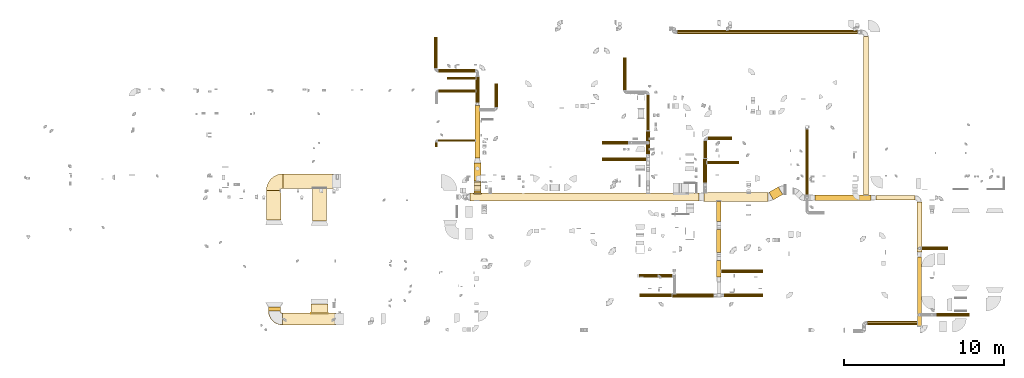
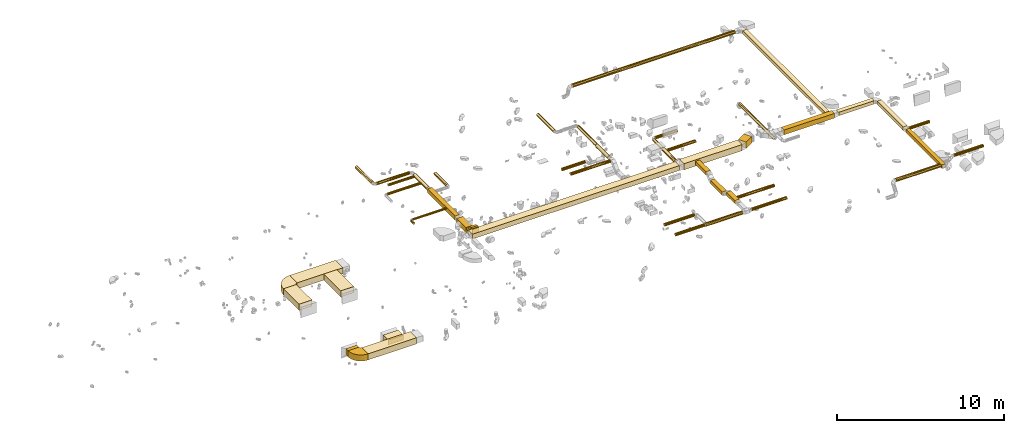
# One storey, part 1 of 62: 54 coverings.
"""IFC2X3 building model written with IfcOpenShell, lengths in millimetres."""

from ifc_helpers import new_model, entity, si_unit, converted_unit, derived_unit, direction, frame, frame_2d, origin, origin_2d_with_axis, place, context, subcontext, project, spatial, polyline, circle_curve, parameter, trimmed, segment, composite_curve, rectangle, circle, outline, extrude, element, save


model = new_model("IFC2X3")

# Units and contexts
model_context = context("Model", 3, precision=0.01, world=origin(), true_north=direction((6.12303176911189e-17, 1.0)))
body_context = subcontext(model_context, "Body", "Model", "MODEL_VIEW")
ifc_project = project(units=[si_unit("LENGTHUNIT", "METRE", prefix="MILLI"), si_unit("AREAUNIT", "SQUARE_METRE"), si_unit("VOLUMEUNIT", "CUBIC_METRE"), converted_unit("PLANEANGLEUNIT", "DEGREE", entity("IfcRatioMeasure", 0.0174532925199433), si_unit("PLANEANGLEUNIT", "RADIAN"), dimensions=[0, 0, 0, 0, 0, 0, 0]), si_unit("MASSUNIT", "GRAM", prefix="KILO"), derived_unit("MASSDENSITYUNIT", [(si_unit("MASSUNIT", "GRAM", prefix="KILO"), 1), (si_unit("LENGTHUNIT", "METRE"), -3)]), derived_unit("MOMENTOFINERTIAUNIT", [(si_unit("LENGTHUNIT", "METRE"), 4)]), si_unit("TIMEUNIT", "SECOND"), si_unit("FREQUENCYUNIT", "HERTZ"), si_unit("THERMODYNAMICTEMPERATUREUNIT", "DEGREE_CELSIUS"), derived_unit("THERMALTRANSMITTANCEUNIT", [(si_unit("MASSUNIT", "GRAM", prefix="KILO"), 1), (si_unit("THERMODYNAMICTEMPERATUREUNIT", "KELVIN"), -1), (si_unit("TIMEUNIT", "SECOND"), -3)]), derived_unit("VOLUMETRICFLOWRATEUNIT", [(si_unit("LENGTHUNIT", "METRE"), 3), (si_unit("TIMEUNIT", "SECOND"), -1)]), derived_unit("MASSFLOWRATEUNIT", [(si_unit("MASSUNIT", "GRAM", prefix="KILO"), 1), (si_unit("TIMEUNIT", "SECOND"), -1)]), derived_unit("ROTATIONALFREQUENCYUNIT", [(si_unit("TIMEUNIT", "SECOND"), -1)]), si_unit("ELECTRICCURRENTUNIT", "AMPERE"), si_unit("ELECTRICVOLTAGEUNIT", "VOLT"), si_unit("POWERUNIT", "WATT"), si_unit("FORCEUNIT", "NEWTON", prefix="KILO"), si_unit("ILLUMINANCEUNIT", "LUX"), si_unit("LUMINOUSFLUXUNIT", "LUMEN"), si_unit("LUMINOUSINTENSITYUNIT", "CANDELA"), derived_unit("USERDEFINED", [(si_unit("MASSUNIT", "GRAM", prefix="KILO"), -1), (si_unit("LENGTHUNIT", "METRE"), -2), (si_unit("TIMEUNIT", "SECOND"), 3), (si_unit("LUMINOUSFLUXUNIT", "LUMEN"), 1)]), derived_unit("LINEARVELOCITYUNIT", [(si_unit("LENGTHUNIT", "METRE"), 1), (si_unit("TIMEUNIT", "SECOND"), -1)]), si_unit("PRESSUREUNIT", "PASCAL"), derived_unit("USERDEFINED", [(si_unit("LENGTHUNIT", "METRE"), -2), (si_unit("MASSUNIT", "GRAM", prefix="KILO"), 1), (si_unit("TIMEUNIT", "SECOND"), -2)]), derived_unit("LINEARFORCEUNIT", [(si_unit("MASSUNIT", "GRAM", prefix="KILO"), 1), (si_unit("LENGTHUNIT", "METRE"), 1), (si_unit("TIMEUNIT", "SECOND"), -2), (si_unit("LENGTHUNIT", "METRE"), -1)]), derived_unit("PLANARFORCEUNIT", [(si_unit("MASSUNIT", "GRAM", prefix="KILO"), 1), (si_unit("LENGTHUNIT", "METRE"), 1), (si_unit("TIMEUNIT", "SECOND"), -2), (si_unit("LENGTHUNIT", "METRE"), -2)])], contexts=[model_context])

# Site, building, storey
site_placement = place(None, origin())
site = spatial("IfcSite", under=ifc_project, at=site_placement, CompositionType="ELEMENT")
building_placement = place(site_placement, origin())
building = spatial("IfcBuilding", under=site, at=building_placement, CompositionType="ELEMENT")
storey_placement = place(building_placement, frame((0.0, 0.0, 24000.0)))
storey = spatial("IfcBuildingStorey", under=building, at=storey_placement, CompositionType="ELEMENT", Elevation=24000.0)

# Coverings
covering_1_placement = place(storey_placement, frame((54240.7, 8649.98, 3325.0)))
element("IfcCovering", 1, at=covering_1_placement, inside=storey, PredefinedType="INSULATION", context=body_context, shape_type="SweptSolid", body=[
    extrude(rectangle(XDim=4013.85955351197, YDim=550.000000000001, at=origin_2d_with_axis()), frame((2006.93, 275.0, 0.0)), (0.0, 0.0, 1.0), 450.000000000002),
])
covering_2_placement = place(storey_placement, frame((58317.05, 8740.41, 3325.0)))
element("IfcCovering", 2, at=covering_2_placement, inside=storey, PredefinedType="INSULATION", context=body_context, shape_type="SweptSolid", body=[
    extrude(rectangle(XDim=672.825030727756, YDim=550.000000000009, at=origin_2d_with_axis()), frame((428.84, 406.36, 0.0), z_axis=(0.0, 0.0, 1.0), x_axis=(0.866025403784441, 0.499999999999996, 0.0)), (0.0, 0.0, 1.0), 450.000000000002),
])
covering_3_placement = place(storey_placement, frame((39617.06, 8674.98, 3375.0)))
element("IfcCovering", 3, at=covering_3_placement, inside=storey, PredefinedType="INSULATION", context=body_context, shape_type="SweptSolid", body=[
    extrude(rectangle(XDim=14323.633695998, YDim=500.000000000001, at=origin_2d_with_axis()), frame((7161.82, 250.0, 0.0), z_axis=(0.0, 0.0, 1.0), x_axis=(-1.0, 0.0, 0.0)), (0.0, 0.0, 1.0), 349.999999999998),
])
covering_4_placement = place(storey_placement, frame((55029.59, 7386.33, 3425.0)))
element("IfcCovering", 4, at=covering_4_placement, inside=storey, PredefinedType="INSULATION", context=body_context, shape_type="SweptSolid", body=[
    extrude(rectangle(XDim=1268.64626439159, YDim=300.000000000001, at=origin_2d_with_axis()), frame((150.0, 634.32, 0.0), z_axis=(0.0, 0.0, 1.0), x_axis=(0.0, -1.0, 0.0)), (0.0, 0.0, 1.0), 250.000000000004),
])
covering_5_placement = place(storey_placement, frame((55029.59, 5448.41, 3125.0)))
element("IfcCovering", 5, at=covering_5_placement, inside=storey, PredefinedType="INSULATION", context=body_context, shape_type="SweptSolid", body=[
    extrude(rectangle(XDim=1430.81282899736, YDim=300.000000000001, at=origin_2d_with_axis()), frame((150.0, 715.41, 0.0), z_axis=(0.0, 0.0, 1.0), x_axis=(0.0, -1.0, 0.0)), (0.0, 0.0, 1.0), 250.000000000004),
])
covering_6_placement = place(storey_placement, frame((55029.59, 3912.24, 3425.0)))
element("IfcCovering", 6, at=covering_6_placement, inside=storey, PredefinedType="INSULATION", context=body_context, shape_type="SweptSolid", body=[
    extrude(rectangle(XDim=1029.05982822021, YDim=300.000000000001, at=origin_2d_with_axis()), frame((150.0, 514.53, 0.0), z_axis=(0.0, 0.0, 1.0), x_axis=(0.0, 1.0, 0.0)), (0.0, 0.0, 1.0), 250.000000000004),
])
covering_7_placement = place(storey_placement, frame((55324.59, 4170.65, 3443.4)))
element("IfcCovering", 7, at=covering_7_placement, inside=storey, PredefinedType="INSULATION", context=body_context, shape_type="SweptSolid", body=[
    extrude(circle(Radius=105.0, at=origin_2d_with_axis()), frame((0.0, 106.6, 106.6), z_axis=(1.0, 0.0, 0.0), x_axis=(0.0, 1.0, 0.0)), (0.0, 0.0, 1.0), 2616.24999999989),
])
covering_8_placement = place(storey_placement, frame((55504.59, 2669.37, 3443.4)))
element("IfcCovering", 8, at=covering_8_placement, inside=storey, PredefinedType="INSULATION", context=body_context, shape_type="SweptSolid", body=[
    extrude(circle(Radius=105.0, at=origin_2d_with_axis()), frame((0.0, 106.6, 106.6), z_axis=(1.0, 0.0, 0.0), x_axis=(0.0, 1.0, 0.0)), (0.0, 0.0, 1.0), 2434.58382599763),
])
covering_9_placement = place(storey_placement, frame((52284.64, 2649.37, 3423.4)))
element("IfcCovering", 9, at=covering_9_placement, inside=storey, PredefinedType="INSULATION", context=body_context, shape_type="SweptSolid", body=[
    extrude(circle(Radius=125.0, at=origin_2d_with_axis()), frame((0.0, 126.6, 126.6), z_axis=(1.0, 0.0, 0.0), x_axis=(0.0, -1.0, 0.0)), (0.0, 0.0, 1.0), 2569.94435033076),
])
covering_10_placement = place(storey_placement, frame((50238.85, 2669.37, 3443.4)))
element("IfcCovering", 10, at=covering_10_placement, inside=storey, PredefinedType="INSULATION", context=body_context, shape_type="SweptSolid", body=[
    extrude(circle(Radius=105.0, at=origin_2d_with_axis()), frame((0.0, 106.6, 106.6), z_axis=(1.0, 0.0, 0.0), x_axis=(0.0, -1.0, 0.0)), (0.0, 0.0, 1.0), 2005.79291070888),
])
covering_11_placement = place(storey_placement, frame((50181.52, 3891.51, 3443.4)))
element("IfcCovering", 11, at=covering_11_placement, inside=storey, PredefinedType="INSULATION", context=body_context, shape_type="SweptSolid", body=[
    extrude(circle(Radius=105.0, at=origin_2d_with_axis()), frame((0.0, 106.6, 106.6), z_axis=(1.0, 0.0, 0.0), x_axis=(0.0, -1.0, 0.0)), (0.0, 0.0, 1.0), 2068.12499999997),
])
covering_12_placement = place(storey_placement, frame((47890.35, 11165.43, 3543.4)))
element("IfcCovering", 12, at=covering_12_placement, inside=storey, PredefinedType="INSULATION", context=body_context, shape_type="SweptSolid", body=[
    extrude(circle(Radius=105.0, at=origin_2d_with_axis()), frame((0.0, 106.6, 106.6), z_axis=(1.0, 0.0, 0.0), x_axis=(0.0, -1.0, 0.0)), (0.0, 0.0, 1.0), 2746.27416997958),
])
covering_13_placement = place(storey_placement, frame((50630.03, 11595.58, 3523.4)))
element("IfcCovering", 13, at=covering_13_placement, inside=storey, PredefinedType="INSULATION", context=body_context, shape_type="SweptSolid", body=[
    extrude(circle(Radius=125.0, at=origin_2d_with_axis()), frame((126.6, 0.0, 126.6), z_axis=(0.0, 1.0, 0.0), x_axis=(-1.0, 0.0, 0.0)), (0.0, 0.0, 1.0), 1444.99999999998),
])
covering_14_placement = place(storey_placement, frame((49195.97, 15621.83, 3543.4)))
element("IfcCovering", 14, at=covering_14_placement, inside=storey, PredefinedType="INSULATION", context=body_context, shape_type="SweptSolid", body=[
    extrude(circle(Radius=105.0, at=origin_2d_with_axis()), frame((106.6, 0.0, 106.6), z_axis=(0.0, 1.0, 0.0), x_axis=(-1.0, 0.0, 0.0)), (0.0, 0.0, 1.0), 2018.74999999999),
])
covering_15_placement = place(storey_placement, frame((50650.03, 13080.58, 3563.4)))
element("IfcCovering", 15, at=covering_15_placement, inside=storey, PredefinedType="INSULATION", context=body_context, shape_type="SweptSolid", body=[
    extrude(circle(Radius=105.0, at=origin_2d_with_axis()), frame((106.6, 0.0, 106.6), z_axis=(0.0, 1.0, 0.0), x_axis=(-1.0, 0.0, 0.0)), (0.0, 0.0, 1.0), 2221.25000000001),
])
covering_16_placement = place(storey_placement, frame((47890.35, 12203.45, 3253.4)))
element("IfcCovering", 16, at=covering_16_placement, inside=storey, PredefinedType="INSULATION", context=body_context, shape_type="SweptSolid", body=[
    extrude(circle(Radius=105.0, at=origin_2d_with_axis()), frame((0.0, 106.6, 106.6), z_axis=(1.0, 0.0, 0.0), x_axis=(0.0, -1.0, 0.0)), (0.0, 0.0, 1.0), 1600.0),
])
covering_17_placement = place(storey_placement, frame((54206.92, 9825.35, 3073.4)))
element("IfcCovering", 17, at=covering_17_placement, inside=storey, PredefinedType="INSULATION", context=body_context, shape_type="SweptSolid", body=[
    extrude(circle(Radius=125.0, at=origin_2d_with_axis()), frame((126.6, 0.0, 126.6), z_axis=(0.0, 1.0, 0.0), x_axis=(1.0, 0.0, 0.0)), (0.0, 0.0, 1.0), 1482.42358986801),
])
covering_18_placement = place(storey_placement, frame((54493.52, 12476.18, 3093.4)))
element("IfcCovering", 18, at=covering_18_placement, inside=storey, PredefinedType="INSULATION", context=body_context, shape_type="SweptSolid", body=[
    extrude(circle(Radius=105.0, at=origin_2d_with_axis()), frame((0.0, 106.6, 106.6), z_axis=(1.0, 0.0, 0.0), x_axis=(0.0, 1.0, 0.0)), (0.0, 0.0, 1.0), 1521.83766184076),
])
covering_19_placement = place(storey_placement, frame((54226.92, 11347.77, 3093.4)))
element("IfcCovering", 19, at=covering_19_placement, inside=storey, PredefinedType="INSULATION", context=body_context, shape_type="SweptSolid", body=[
    extrude(circle(Radius=105.0, at=origin_2d_with_axis()), frame((106.6, 0.0, 106.6), z_axis=(0.0, 1.0, 0.0), x_axis=(1.0, 0.0, 0.0)), (0.0, 0.0, 1.0), 1075.00000000004),
])
covering_20_placement = place(storey_placement, frame((54453.52, 10971.22, 3093.4)))
element("IfcCovering", 20, at=covering_20_placement, inside=storey, PredefinedType="INSULATION", context=body_context, shape_type="SweptSolid", body=[
    extrude(circle(Radius=105.0, at=origin_2d_with_axis()), frame((0.0, 106.6, 106.6), z_axis=(1.0, 0.0, 0.0), x_axis=(0.0, 1.0, 0.0)), (0.0, 0.0, 1.0), 1980.0),
])
covering_21_placement = place(storey_placement, frame((61191.73, 8700.02, 3425.0)))
element("IfcCovering", 21, at=covering_21_placement, inside=storey, PredefinedType="INSULATION", context=body_context, shape_type="SweptSolid", body=[
    extrude(rectangle(XDim=3500.00000000001, YDim=350.000000000001, at=origin_2d_with_axis()), frame((1750.0, 175.0, 0.0)), (0.0, 0.0, 1.0), 349.999999999998),
])
covering_22_placement = place(storey_placement, frame((64991.73, 8725.02, 3475.0)))
element("IfcCovering", 22, at=covering_22_placement, inside=storey, PredefinedType="INSULATION", context=body_context, shape_type="SweptSolid", body=[
    extrude(rectangle(XDim=2449.99999999995, YDim=300.000000000001, at=origin_2d_with_axis()), frame((1225.0, 150.0, 0.0)), (0.0, 0.0, 1.0), 250.000000000004),
])
covering_23_placement = place(storey_placement, frame((67566.73, 5468.12, 3475.0)))
element("IfcCovering", 23, at=covering_23_placement, inside=storey, PredefinedType="INSULATION", context=body_context, shape_type="SweptSolid", body=[
    extrude(rectangle(XDim=3131.89999999988, YDim=300.000000000001, at=origin_2d_with_axis()), frame((150.0, 1565.95, 0.0), z_axis=(0.0, 0.0, 1.0), x_axis=(0.0, -1.0, 0.0)), (0.0, 0.0, 1.0), 250.000000000004),
])
covering_24_placement = place(storey_placement, frame((67591.73, 868.12, 3475.0)))
element("IfcCovering", 24, at=covering_24_placement, inside=storey, PredefinedType="INSULATION", context=body_context, shape_type="SweptSolid", body=[
    extrude(rectangle(XDim=4300.00000000001, YDim=249.999999999995, at=origin_2d_with_axis()), frame((125.0, 2150.0, 0.0), z_axis=(0.0, 0.0, 1.0), x_axis=(0.0, -1.0, 0.0)), (0.0, 0.0, 1.0), 250.000000000008),
])
covering_25_placement = place(storey_placement, frame((60582.25, 9055.62, 3053.4)))
element("IfcCovering", 25, at=covering_25_placement, inside=storey, PredefinedType="INSULATION", context=body_context, shape_type="SweptSolid", body=[
    extrude(circle(Radius=105.0, at=origin_2d_with_axis()), frame((106.6, 0.0, 106.6), z_axis=(0.0, 1.0, 0.0), x_axis=(1.0, 0.0, 0.0)), (0.0, 0.0, 1.0), 4090.0),
])
covering_26_placement = place(storey_placement, frame((64232.65, 9045.02, 3525.0)))
element("IfcCovering", 26, at=covering_26_placement, inside=storey, PredefinedType="INSULATION", context=body_context, shape_type="SweptSolid", body=[
    extrude(rectangle(XDim=9908.10000000008, YDim=300.000000000001, at=origin_2d_with_axis()), frame((150.0, 4954.05, 0.0), z_axis=(0.0, 0.0, 1.0), x_axis=(0.0, 1.0, 0.0)), (0.0, 0.0, 1.0), 250.000000000004),
])
covering_27_placement = place(storey_placement, frame((52590.65, 19101.53, 3523.4)))
element("IfcCovering", 27, at=covering_27_placement, inside=storey, PredefinedType="INSULATION", context=body_context, shape_type="SweptSolid", body=[
    extrude(circle(Radius=125.0, at=origin_2d_with_axis()), frame((0.0, 126.6, 126.6), z_axis=(1.0, 0.0, 0.0), x_axis=(0.0, -1.0, 0.0)), (0.0, 0.0, 1.0), 11251.9965340593),
])
covering_28_placement = place(storey_placement, frame((67876.73, 5604.78, 3193.4)))
element("IfcCovering", 28, at=covering_28_placement, inside=storey, PredefinedType="INSULATION", context=body_context, shape_type="SweptSolid", body=[
    extrude(circle(Radius=105.0, at=origin_2d_with_axis()), frame((0.0, 106.6, 106.6), z_axis=(1.0, 0.0, 0.0), x_axis=(0.0, 1.0, 0.0)), (0.0, 0.0, 1.0), 1640.00000000001),
])
covering_29_placement = place(storey_placement, frame((68803.0, 1444.8, 3493.4)))
element("IfcCovering", 29, at=covering_29_placement, inside=storey, PredefinedType="INSULATION", context=body_context, shape_type="SweptSolid", body=[
    extrude(circle(Radius=105.0, at=origin_2d_with_axis()), frame((0.0, 106.6, 106.6), z_axis=(1.0, 0.0, 0.0), x_axis=(0.0, 1.0, 0.0)), (0.0, 0.0, 1.0), 2033.72583002031),
])
covering_30_placement = place(storey_placement, frame((64469.87, 923.29, 3473.4)))
element("IfcCovering", 30, at=covering_30_placement, inside=storey, PredefinedType="INSULATION", context=body_context, shape_type="SweptSolid", body=[
    extrude(circle(Radius=125.0, at=origin_2d_with_axis()), frame((0.0, 126.6, 126.6), z_axis=(1.0, 0.0, 0.0), x_axis=(0.0, -1.0, 0.0)), (0.0, 0.0, 1.0), 3126.86241545841),
])
covering_31_placement = place(storey_placement, frame((39945.11, 11346.34, 3020.0)))
element("IfcCovering", 31, at=covering_31_placement, inside=storey, PredefinedType="INSULATION", context=body_context, shape_type="SweptSolid", body=[
    extrude(rectangle(XDim=3279.99999999988, YDim=300.000000000001, at=origin_2d_with_axis()), frame((150.0, 1640.0, 0.0), z_axis=(0.0, 0.0, 1.0), x_axis=(0.0, -1.0, 0.0)), (0.0, 0.0, 1.0), 300.000000000001),
])
covering_32_placement = place(storey_placement, frame((39870.11, 9933.64, 2995.0)))
element("IfcCovering", 32, at=covering_32_placement, inside=storey, PredefinedType="INSULATION", context=body_context, shape_type="SweptSolid", body=[
    extrude(rectangle(XDim=1112.69724297037, YDim=450.000000000002, at=origin_2d_with_axis()), frame((225.0, 556.35, 0.0), z_axis=(0.0, 0.0, 1.0), x_axis=(0.0, -1.0, 0.0)), (0.0, 0.0, 1.0), 349.999999999998),
])
covering_33_placement = place(storey_placement, frame((39870.11, 9118.88, 3375.0)))
element("IfcCovering", 33, at=covering_33_placement, inside=storey, PredefinedType="INSULATION", context=body_context, shape_type="SweptSolid", body=[
    extrude(rectangle(XDim=450.000000000002, YDim=51.0959999999994, at=origin_2d_with_axis()), frame((225.0, 25.55, 0.0), z_axis=(0.0, 0.0, 1.0), x_axis=(-1.0, 0.0, 0.0)), (0.0, 0.0, 1.0), 349.999999999998),
])
covering_34_placement = place(storey_placement, frame((39870.11, 9169.98, 3375.0)))
element("IfcCovering", 34, at=covering_34_placement, inside=storey, PredefinedType="INSULATION", context=body_context, shape_type="SweptSolid", body=[
    extrude(rectangle(XDim=135.135931288061, YDim=450.000000000002, at=origin_2d_with_axis()), frame((225.0, 67.57, 0.0), z_axis=(0.0, 0.0, 1.0), x_axis=(0.0, 1.0, 0.0)), (0.0, 0.0, 1.0), 349.999999999998),
])
covering_35_placement = place(storey_placement, frame((39870.11, 9393.5, 3134.12)))
element("IfcCovering", 35, at=covering_35_placement, inside=storey, PredefinedType="INSULATION", context=body_context, shape_type="SweptSolid", body=[
    extrude(rectangle(XDim=288.873016277932, YDim=350.000000000001, at=origin_2d_with_axis()), frame((0.0, 225.88, 225.88), z_axis=(1.0, 0.0, 0.0), x_axis=(0.0, -0.707106781186548, 0.707106781186548)), (0.0, 0.0, 1.0), 450.000000000001),
])
covering_36_placement = place(storey_placement, frame((37617.21, 12378.51, 3123.4)))
element("IfcCovering", 36, at=covering_36_placement, inside=storey, PredefinedType="INSULATION", context=body_context, shape_type="SweptSolid", body=[
    extrude(circle(Radius=75.0, at=origin_2d_with_axis()), frame((0.0, 76.6, 76.6), z_axis=(1.0, 0.0, 0.0), x_axis=(0.0, -1.0, 0.0)), (0.0, 0.0, 1.0), 2332.89999999999),
])
covering_37_placement = place(storey_placement, frame((37440.61, 12045.11, 3123.4)))
element("IfcCovering", 37, at=covering_37_placement, inside=storey, PredefinedType="INSULATION", context=body_context, shape_type="SweptSolid", body=[
    extrude(circle(Radius=75.0, at=origin_2d_with_axis()), frame((76.6, 0.0, 76.6), z_axis=(0.0, 1.0, 0.0), x_axis=(1.0, 0.0, 0.0)), (0.0, 0.0, 1.0), 310.000000000025),
])
covering_38_placement = place(storey_placement, frame((41159.36, 14540.86, 3043.4)))
element("IfcCovering", 38, at=covering_38_placement, inside=storey, PredefinedType="INSULATION", context=body_context, shape_type="SweptSolid", body=[
    extrude(circle(Radius=105.0, at=origin_2d_with_axis()), frame((106.6, 0.0, 106.6), z_axis=(0.0, 1.0, 0.0), x_axis=(-1.0, 0.0, 0.0)), (0.0, 0.0, 1.0), 1480.00000000001),
])
covering_39_placement = place(storey_placement, frame((39968.51, 14826.34, 3043.4)))
element("IfcCovering", 39, at=covering_39_placement, inside=storey, PredefinedType="INSULATION", context=body_context, shape_type="SweptSolid", body=[
    extrude(circle(Radius=125.0, at=origin_2d_with_axis()), frame((126.6, 0.0, 126.6), z_axis=(0.0, 1.0, 0.0), x_axis=(-1.0, 0.0, 0.0)), (0.0, 0.0, 1.0), 1619.99999999999),
])
covering_40_placement = place(storey_placement, frame((37652.21, 16709.74, 3063.4)))
element("IfcCovering", 40, at=covering_40_placement, inside=storey, PredefinedType="INSULATION", context=body_context, shape_type="SweptSolid", body=[
    extrude(circle(Radius=105.0, at=origin_2d_with_axis()), frame((0.0, 106.6, 106.6), z_axis=(1.0, 0.0, 0.0), x_axis=(0.0, -1.0, 0.0)), (0.0, 0.0, 1.0), 2282.90000000014),
])
covering_41_placement = place(storey_placement, frame((37385.61, 16976.34, 3063.4)))
element("IfcCovering", 41, at=covering_41_placement, inside=storey, PredefinedType="INSULATION", context=body_context, shape_type="SweptSolid", body=[
    extrude(circle(Radius=105.0, at=origin_2d_with_axis()), frame((106.6, 0.0, 106.6), z_axis=(0.0, 1.0, 0.0), x_axis=(-1.0, 0.0, 0.0)), (0.0, 0.0, 1.0), 1949.99999999999),
])
covering_42_placement = place(storey_placement, frame((37657.21, 15450.99, 3080.9)))
element("IfcCovering", 42, at=covering_42_placement, inside=storey, PredefinedType="INSULATION", context=body_context, shape_type="SweptSolid", body=[
    extrude(circle(Radius=87.5, at=origin_2d_with_axis()), frame((0.0, 89.1, 89.1), z_axis=(1.0, 0.0, 0.0), x_axis=(0.0, -1.0, 0.0)), (0.0, 0.0, 1.0), 2317.90000000006),
])
covering_43_placement = place(storey_placement, frame((38202.21, 16250.07, 3080.9)))
element("IfcCovering", 43, at=covering_43_placement, inside=storey, PredefinedType="INSULATION", context=body_context, shape_type="SweptSolid", body=[
    extrude(circle(Radius=87.5, at=origin_2d_with_axis()), frame((0.0, 89.1, 89.1), z_axis=(1.0, 0.0, 0.0), x_axis=(0.0, -1.0, 0.0)), (0.0, 0.0, 1.0), 1772.90000000006),
])
covering_44_placement = place(storey_placement, frame((27930.62, 9464.97, 3325.0)))
element("IfcCovering", 44, at=covering_44_placement, inside=storey, PredefinedType="INSULATION", context=body_context, shape_type="SweptSolid", body=[
    extrude(rectangle(XDim=3164.67871385249, YDim=899.999999999999, at=origin_2d_with_axis()), frame((1582.34, 450.0, 0.0), z_axis=(0.0, 0.0, 1.0), x_axis=(-1.0, 0.0, 0.0)), (0.0, 0.0, 1.0), 450.000000000002),
])
covering_45_placement = place(storey_placement, frame((26905.62, 7474.06, 3325.0)))
element("IfcCovering", 45, at=covering_45_placement, inside=storey, PredefinedType="INSULATION", context=body_context, shape_type="SweptSolid", body=[
    extrude(rectangle(XDim=1865.90580735633, YDim=900.000000000003, at=origin_2d_with_axis()), frame((450.0, 932.95, 0.0), z_axis=(0.0, 0.0, 1.0), x_axis=(0.0, 1.0, 0.0)), (0.0, 0.0, 1.0), 450.000000000002),
])
covering_46_placement = place(storey_placement, frame((29774.65, 7432.81, 3325.0)))
element("IfcCovering", 46, at=covering_46_placement, inside=storey, PredefinedType="INSULATION", context=body_context, shape_type="SweptSolid", body=[
    extrude(rectangle(XDim=2037.15580735656, YDim=900.000000000003, at=origin_2d_with_axis()), frame((450.0, 1018.58, 0.0), z_axis=(0.0, 0.0, 1.0), x_axis=(0.0, -1.0, 0.0)), (0.0, 0.0, 1.0), 450.000000000002),
])
covering_47_placement = place(storey_placement, frame((27900.62, 919.06, 3325.0)))
element("IfcCovering", 47, at=covering_47_placement, inside=storey, PredefinedType="INSULATION", context=body_context, shape_type="SweptSolid", body=[
    extrude(rectangle(XDim=3350.88242033331, YDim=750.0, at=origin_2d_with_axis()), frame((1675.44, 375.0, 0.0), z_axis=(0.0, 0.0, 1.0), x_axis=(-1.0, 0.0, 0.0)), (0.0, 0.0, 1.0), 450.000000000002),
])
covering_48_placement = place(storey_placement, frame((29699.65, 1664.06, 3375.0)))
element("IfcCovering", 48, at=covering_48_placement, inside=storey, PredefinedType="INSULATION", context=body_context, shape_type="SweptSolid", body=[
    extrude(rectangle(XDim=568.74999999973, YDim=1050.0, at=origin_2d_with_axis()), frame((525.0, 284.37, 0.0), z_axis=(0.0, 0.0, 1.0), x_axis=(0.0, 1.0, 0.0)), (0.0, 0.0, 1.0), 349.999999999998),
])
covering_49_placement = place(storey_placement, frame((29699.65, 1612.96, 3375.0)))
element("IfcCovering", 49, at=covering_49_placement, inside=storey, PredefinedType="INSULATION", context=body_context, shape_type="SweptSolid", body=[
    extrude(rectangle(XDim=1050.0, YDim=51.0959999999994, at=origin_2d_with_axis()), frame((525.0, 25.55, 0.0), z_axis=(0.0, 0.0, 1.0), x_axis=(-1.0, 0.0, 0.0)), (0.0, 0.0, 1.0), 349.999999999998),
])
covering_50_placement = place(storey_placement, frame((27025.62, 1794.06, 3325.0)))
element("IfcCovering", 50, at=covering_50_placement, inside=storey, PredefinedType="INSULATION", context=body_context, shape_type="SweptSolid", body=[
    extrude(rectangle(XDim=239.999999999895, YDim=750.000000000003, at=origin_2d_with_axis()), frame((375.0, 120.0, 0.0), z_axis=(0.0, 0.0, 1.0), x_axis=(0.0, 1.0, 0.0)), (0.0, 0.0, 1.0), 450.000000000002),
])
covering_51_placement = place(storey_placement, frame((39870.11, 9596.17, 2993.4)))
element("IfcCovering", 51, at=covering_51_placement, inside=storey, PredefinedType="INSULATION", context=body_context, shape_type="SweptSolid", body=[
    extrude(outline(composite_curve([segment(polyline([(-131.07, -106.07), (218.93, -106.07)]), True, "CONTINUOUS"), segment(trimmed(circle_curve(frame_2d((-256.07, -106.07), x_axis=(0.707106781186553, 0.707106781186553)), 475.0), [parameter(315.0)], [parameter(0.0)], True, "PARAMETER"), True, "CONTINUOUS"), segment(polyline([(79.81, 229.81), (-167.68, -17.68)]), True, "CONTINUOUS"), segment(trimmed(circle_curve(frame_2d((-256.07, -106.07), x_axis=(0.707106781186553, 0.707106781186553)), 125.0), [parameter(315.0)], [parameter(360.0)], True, "PARAMETER"), False, "CONTINUOUS")], self_intersect=False)), frame((0.0, 231.4, 220.53), z_axis=(1.0, 0.0, 0.0), x_axis=(0.0, -0.707106781186546, -0.707106781186549)), (0.0, 0.0, 1.0), 450.000000000002),
])
covering_52_placement = place(storey_placement, frame((39870.11, 9303.52, 3336.79)))
element("IfcCovering", 52, at=covering_52_placement, inside=storey, PredefinedType="INSULATION", context=body_context, shape_type="SweptSolid", body=[
    extrude(outline(composite_curve([segment(polyline([(-131.07, -106.07), (218.93, -106.07)]), True, "CONTINUOUS"), segment(trimmed(circle_curve(frame_2d((-256.07, -106.07), x_axis=(0.707106781186553, 0.707106781186553)), 475.0), [parameter(315.0)], [parameter(0.0)], True, "PARAMETER"), True, "CONTINUOUS"), segment(polyline([(79.81, 229.81), (-167.68, -17.68)]), True, "CONTINUOUS"), segment(trimmed(circle_curve(frame_2d((-256.07, -106.07), x_axis=(0.707106781186553, 0.707106781186553)), 125.0), [parameter(315.0)], [parameter(360.0)], True, "PARAMETER"), False, "CONTINUOUS")], self_intersect=False)), frame((0.0, 107.66, 169.27), z_axis=(1.0, 0.0, 0.0), x_axis=(0.0, 0.707106781186548, 0.707106781186548)), (0.0, 0.0, 1.0), 450.000000000002),
])
covering_53_placement = place(storey_placement, frame((26904.02, 9338.37, 3325.0)))
element("IfcCovering", 53, at=covering_53_placement, inside=storey, PredefinedType="INSULATION", context=body_context, shape_type="SweptSolid", body=[
    extrude(outline(composite_curve([segment(polyline([(-287.5, 162.5), (-287.5, -737.5)]), True, "CONTINUOUS"), segment(trimmed(circle_curve(frame_2d((-287.5, 287.5), x_axis=(1.0, 0.0)), 1025.0), [parameter(270.0)], [parameter(0.0)], True, "PARAMETER"), True, "CONTINUOUS"), segment(polyline([(737.5, 287.5), (-162.5, 287.5)]), True, "CONTINUOUS"), segment(trimmed(circle_curve(frame_2d((-287.5, 287.5), x_axis=(1.0, 0.0)), 125.0), [parameter(270.0)], [parameter(360.0)], True, "PARAMETER"), False, "CONTINUOUS")], self_intersect=False)), frame((739.1, 289.1, 0.0), z_axis=(0.0, 0.0, -1.0), x_axis=(0.0, 1.0, 0.0)), (0.0, 0.0, -1.0), 450.000000000002),
])
covering_54_placement = place(storey_placement, frame((27024.02, 917.47, 3325.0)))
element("IfcCovering", 54, at=covering_54_placement, inside=storey, PredefinedType="INSULATION", context=body_context, shape_type="SweptSolid", body=[
    extrude(outline(composite_curve([segment(polyline([(-250.0, 125.0), (-250.0, -625.0)]), True, "CONTINUOUS"), segment(trimmed(circle_curve(frame_2d((-250.0, 250.0), x_axis=(1.0, 0.0)), 875.0), [parameter(269.999999999998)], [parameter(0.0)], True, "PARAMETER"), True, "CONTINUOUS"), segment(polyline([(625.0, 250.0), (-125.0, 250.0)]), True, "CONTINUOUS"), segment(trimmed(circle_curve(frame_2d((-250.0, 250.0), x_axis=(1.0, 0.0)), 125.0), [parameter(269.999999999998)], [parameter(360.0)], True, "PARAMETER"), False, "CONTINUOUS")], self_intersect=False)), frame((626.6, 626.6, 0.0), z_axis=(0.0, 0.0, -1.0), x_axis=(-1.0, 0.0, 0.0)), (0.0, 0.0, -1.0), 450.000000000002),
])

save(model, "model.ifc")
